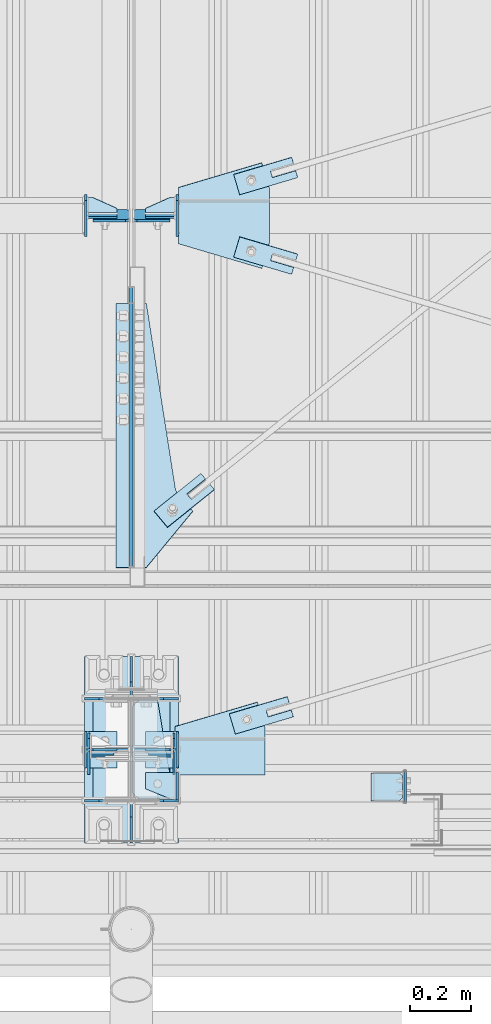
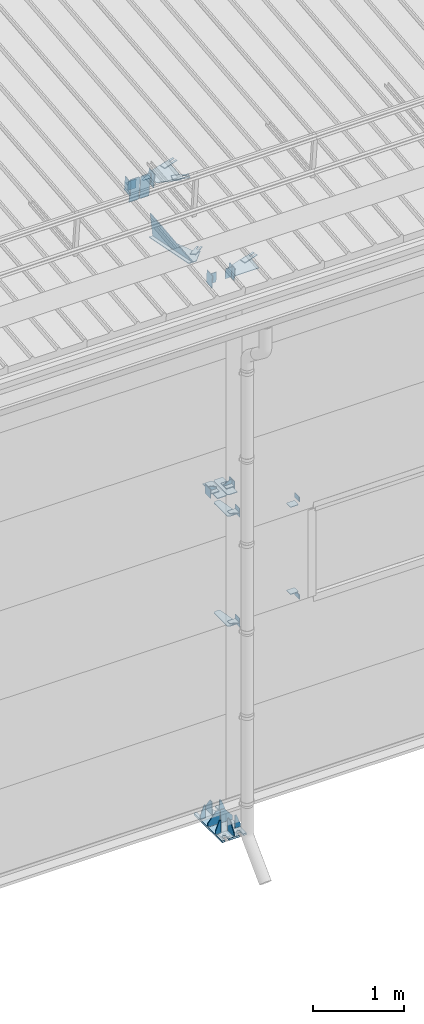
# One storey, part 145 of 709: 47 plates, 7 openings, 15 elements without a shape of their own.
"""IFC4 building model written with IfcOpenShell, lengths in millimetres."""

from ifc_helpers import new_model, si_unit, direction, frame, origin_with_axes, place, context, subcontext, project, spatial, line, arc, indexed_curve, outline, extrude, material, element, aggregate, save


model = new_model("IFC4")

# Units and contexts
model_context = context("Model", 3, precision=0.2, world=origin_with_axes(), true_north=direction((0.0, 1.0)))
body_context = subcontext(model_context, "Body", "Model", "MODEL_VIEW")
ifc_project = project(units=[si_unit("LENGTHUNIT", "METRE", prefix="MILLI"), si_unit("AREAUNIT", "SQUARE_METRE"), si_unit("VOLUMEUNIT", "CUBIC_METRE"), si_unit("MASSUNIT", "GRAM", prefix="KILO"), si_unit("TIMEUNIT", "SECOND"), si_unit("PLANEANGLEUNIT", "RADIAN"), si_unit("SOLIDANGLEUNIT", "STERADIAN"), si_unit("THERMODYNAMICTEMPERATUREUNIT", "DEGREE_CELSIUS"), si_unit("LUMINOUSINTENSITYUNIT", "LUMEN")], contexts=[model_context])

# Site, building, storey
site_placement = place(None, origin_with_axes())
site = spatial("IfcSite", under=ifc_project, at=site_placement, CompositionType="ELEMENT")
building_placement = place(site_placement, origin_with_axes())
building = spatial("IfcBuilding", under=site, at=building_placement, Name="Undefined", CompositionType="ELEMENT")
storey_placement = place(building_placement, origin_with_axes())
storey = spatial("IfcBuildingStorey", under=building, at=storey_placement, Name="Undefined", CompositionType="ELEMENT", Elevation=0.0)

# Assembly, plates, voiding features
assembly_1_placement = place(storey_placement, frame((40000.0, 173.0, -200.0), z_axis=(-1.0, 0.0, 0.0), x_axis=(0.0, 0.0, 1.0)))
assembly_1 = element("IfcElementAssembly", 1, at=assembly_1_placement, inside=storey)
ifc_material = material(Name="C355-6", Category="STEEL")
plate_1_placement = place(assembly_1_placement, frame((25.0, 168.5, -87.0), z_axis=(0.0, -1.0, 0.0), x_axis=(0.0, 0.0, -1.0)))
plate_1 = element("IfcPlate", 2, at=plate_1_placement, material=ifc_material, ObjectType="419", context=body_context, shape_type="SolidModel", body=[
    extrude(outline(indexed_curve([(0.0, 0.0), (68.0, 0.0), (68.0, 50.0), (20.0, 175.0), (0.0, 175.0)], segments=[line(1, 2, 3, 4, 5, 1)])), frame((0.0, 0.0, 4.0), z_axis=(0.0, 0.0, 1.0), x_axis=(1.0, 0.0, 0.0)), (0.0, 0.0, -1.0), 8.0),
])
plate_2_placement = place(assembly_1_placement, frame((25.0, -168.5, -87.0), z_axis=(0.0, -1.0, 0.0), x_axis=(0.0, 0.0, -1.0)))
plate_2 = element("IfcPlate", 3, at=plate_2_placement, material=ifc_material, ObjectType="419", context=body_context, shape_type="SolidModel", body=[
    extrude(outline(indexed_curve([(0.0, 0.0), (68.0, 0.0), (68.0, 50.0), (20.0, 175.0), (0.0, 175.0)], segments=[line(1, 2, 3, 4, 5, 1)])), frame((0.0, 0.0, 4.0), z_axis=(0.0, 0.0, 1.0), x_axis=(1.0, 0.0, 0.0)), (0.0, 0.0, -1.0), 8.0),
])
plate_3_placement = place(assembly_1_placement, frame((25.0, 173.0, 0.0), z_axis=(0.0, 0.0, -1.0), x_axis=(0.0, 1.0, 0.0)))
plate_3 = element("IfcPlate", 4, at=plate_3_placement, material=ifc_material, ObjectType="418", context=body_context, shape_type="SolidModel", body=[
    extrude(outline(indexed_curve([(0.0, 0.0), (135.0, 0.0), (135.0, 50.0), (50.0, 175.0), (0.0, 175.0)], segments=[line(1, 2, 3, 4, 5, 1)])), frame((0.0, 0.0, 4.0), z_axis=(0.0, 0.0, 1.0), x_axis=(1.0, 0.0, 0.0)), (0.0, 0.0, -1.0), 8.0),
])
plate_4_placement = place(assembly_1_placement, frame((25.0, 0.0, 3.0), z_axis=(0.0, 1.0, 0.0), x_axis=(0.0, 0.0, 1.0)))
plate_4 = element("IfcPlate", 5, at=plate_4_placement, material=ifc_material, ObjectType="417", context=body_context, shape_type="SolidModel", body=[
    extrude(outline(indexed_curve([(0.0, 0.0), (152.0, 0.0), (152.0, 50.0), (50.0, 175.0), (0.0, 175.0)], segments=[line(1, 2, 3, 4, 5, 1)])), frame((0.0, 0.0, 4.0), z_axis=(0.0, 0.0, 1.0), x_axis=(1.0, 0.0, 0.0)), (0.0, 0.0, -1.0), 8.0),
])
plate_5_placement = place(assembly_1_placement, frame((25.0, -168.5, 87.0), z_axis=(0.0, 1.0, 0.0), x_axis=(0.0, 0.0, 1.0)))
plate_5 = element("IfcPlate", 6, at=plate_5_placement, material=ifc_material, ObjectType="419", context=body_context, shape_type="SolidModel", body=[
    extrude(outline(indexed_curve([(0.0, 0.0), (68.0, 0.0), (68.0, 50.0), (20.0, 175.0), (0.0, 175.0)], segments=[line(1, 2, 3, 4, 5, 1)])), frame((0.0, 0.0, 4.0), z_axis=(0.0, 0.0, 1.0), x_axis=(1.0, 0.0, 0.0)), (0.0, 0.0, -1.0), 8.0),
])
plate_6_placement = place(assembly_1_placement, frame((25.0, 0.0, -3.0), z_axis=(0.0, -1.0, 0.0), x_axis=(0.0, 0.0, -1.0)))
plate_6 = element("IfcPlate", 7, at=plate_6_placement, material=ifc_material, ObjectType="417", context=body_context, shape_type="SolidModel", body=[
    extrude(outline(indexed_curve([(0.0, 0.0), (152.0, 0.0), (152.0, 50.0), (50.0, 175.0), (0.0, 175.0)], segments=[line(1, 2, 3, 4, 5, 1)])), frame((0.0, 0.0, 4.0), z_axis=(0.0, 0.0, 1.0), x_axis=(1.0, 0.0, 0.0)), (0.0, 0.0, -1.0), 8.0),
])
plate_7_placement = place(assembly_1_placement, frame((25.0, 168.5, 87.0), z_axis=(0.0, 1.0, 0.0), x_axis=(0.0, 0.0, 1.0)))
plate_7 = element("IfcPlate", 8, at=plate_7_placement, material=ifc_material, ObjectType="419", context=body_context, shape_type="SolidModel", body=[
    extrude(outline(indexed_curve([(0.0, 0.0), (68.0, 0.0), (68.0, 50.0), (20.0, 175.0), (0.0, 175.0)], segments=[line(1, 2, 3, 4, 5, 1)])), frame((0.0, 0.0, 4.0), z_axis=(0.0, 0.0, 1.0), x_axis=(1.0, 0.0, 0.0)), (0.0, 0.0, -1.0), 8.0),
])
plate_8_placement = place(assembly_1_placement, frame((12.5, -308.0, 155.0), z_axis=(1.0, 0.0, 0.0), x_axis=(0.0, 0.0, -1.0)))
plate_8 = element("IfcPlate", 9, at=plate_8_placement, material=ifc_material, ObjectType="416", context=body_context, shape_type="SolidModel", body=[
    extrude(outline(indexed_curve([(0.0, 0.0), (310.0, 0.0), (310.0, 616.0), (0.0, 616.0)], segments=[line(1, 2, 3, 4, 1)])), frame((0.0, 0.0, 12.5), z_axis=(0.0, 0.0, 1.0), x_axis=(1.0, 0.0, 0.0)), (0.0, 0.0, -1.0), 25.0),
])
voiding_feature_1_placement = place(plate_8_placement, frame((40.0, 616.0, 0.0), z_axis=(0.0, 0.0, -1.0), x_axis=(1.0, 0.0, 0.0)))
element("IfcVoidingFeature", 10, at=voiding_feature_1_placement, cuts=plate_8, PredefinedType="HOLE", context=body_context, shape_type="SolidModel", body=[
    extrude(outline(indexed_curve([(0.0, 0.0), (50.0, 0.0), (50.0, 60.0), (42.67767, 77.67767), (25.0, 85.0), (25.0, 85.0), (7.32233, 77.67767), (0.0, 60.0)], segments=[line(1, 2, 3), arc(3, 4, 5), line(5, 6), arc(6, 7, 8), line(8, 1)])), frame((0.0, 0.0, 12.5), z_axis=(0.0, 0.0, 1.0), x_axis=(1.0, 0.0, 0.0)), (0.0, 0.0, -1.0), 25.0),
])
voiding_feature_2_placement = place(plate_8_placement, frame((40.0, 0.0, 0.0), z_axis=(0.0, 0.0, 1.0), x_axis=(1.0, 0.0, 0.0)))
element("IfcVoidingFeature", 11, at=voiding_feature_2_placement, cuts=plate_8, PredefinedType="HOLE", context=body_context, shape_type="SolidModel", body=[
    extrude(outline(indexed_curve([(0.0, 0.0), (50.0, 0.0), (50.0, 60.0), (42.67767, 77.67767), (25.0, 85.0), (25.0, 85.0), (7.32233, 77.67767), (0.0, 60.0)], segments=[line(1, 2, 3), arc(3, 4, 5), line(5, 6), arc(6, 7, 8), line(8, 1)])), frame((0.0, 0.0, 12.5), z_axis=(0.0, 0.0, 1.0), x_axis=(1.0, 0.0, 0.0)), (0.0, 0.0, -1.0), 25.0),
])
voiding_feature_3_placement = place(plate_8_placement, frame((270.0, 616.0, 0.0), z_axis=(0.0, 0.0, 1.0), x_axis=(-1.0, 0.0, 0.0)))
element("IfcVoidingFeature", 12, at=voiding_feature_3_placement, cuts=plate_8, PredefinedType="HOLE", context=body_context, shape_type="SolidModel", body=[
    extrude(outline(indexed_curve([(0.0, 0.0), (50.0, 0.0), (50.0, 60.0), (42.67767, 77.67767), (25.0, 85.0), (25.0, 85.0), (7.32233, 77.67767), (0.0, 60.0)], segments=[line(1, 2, 3), arc(3, 4, 5), line(5, 6), arc(6, 7, 8), line(8, 1)])), frame((0.0, 0.0, 12.5), z_axis=(0.0, 0.0, 1.0), x_axis=(1.0, 0.0, 0.0)), (0.0, 0.0, -1.0), 25.0),
])
voiding_feature_4_placement = place(plate_8_placement, frame((270.0, 0.0, 0.0), z_axis=(0.0, 0.0, -1.0), x_axis=(-1.0, 0.0, 0.0)))
element("IfcVoidingFeature", 13, at=voiding_feature_4_placement, cuts=plate_8, PredefinedType="HOLE", context=body_context, shape_type="SolidModel", body=[
    extrude(outline(indexed_curve([(0.0, 0.0), (50.0, 0.0), (50.0, 60.0), (42.67767, 77.67767), (25.0, 85.0), (25.0, 85.0), (7.32233, 77.67767), (0.0, 60.0)], segments=[line(1, 2, 3), arc(3, 4, 5), line(5, 6), arc(6, 7, 8), line(8, 1)])), frame((0.0, 0.0, 12.5), z_axis=(0.0, 0.0, 1.0), x_axis=(1.0, 0.0, 0.0)), (0.0, 0.0, -1.0), 25.0),
])
plate_9_placement = place(assembly_1_placement, frame((25.0, -173.0, 0.0), z_axis=(0.0, 0.0, 1.0), x_axis=(0.0, -1.0, 0.0)))
plate_9 = element("IfcPlate", 14, at=plate_9_placement, material=ifc_material, ObjectType="418", context=body_context, shape_type="SolidModel", body=[
    extrude(outline(indexed_curve([(0.0, 0.0), (135.0, 0.0), (135.0, 50.0), (50.0, 175.0), (0.0, 175.0)], segments=[line(1, 2, 3, 4, 5, 1)])), frame((0.0, 0.0, 4.0), z_axis=(0.0, 0.0, 1.0), x_axis=(1.0, 0.0, 0.0)), (0.0, 0.0, -1.0), 8.0),
])
plate_10_placement = place(assembly_1_placement, frame((4502.0, 163.0, 127.0), z_axis=(-1.0, 0.0, 0.0), x_axis=(0.0, 0.0, -1.0)))
plate_10 = element("IfcPlate", 15, at=plate_10_placement, material=ifc_material, ObjectType="547", context=body_context, shape_type="SolidModel", body=[
    extrude(outline(indexed_curve([(0.0, 0.0), (108.0, 0.0), (123.0, 15.0), (123.0, 311.0), (108.0, 326.0), (0.0, 326.0)], segments=[line(1, 2, 3, 4, 5, 6, 1)])), frame((0.0, 0.0, 4.0), z_axis=(0.0, 0.0, 1.0), x_axis=(1.0, 0.0, 0.0)), (0.0, 0.0, -1.0), 8.0),
])
plate_11_placement = place(assembly_1_placement, frame((2742.0, -163.0, -4.0), z_axis=(1.0, 0.0, 0.0), x_axis=(0.0, 0.0, -1.0)))
plate_11 = element("IfcPlate", 16, at=plate_11_placement, material=ifc_material, ObjectType="543", context=body_context, shape_type="SolidModel", body=[
    extrude(outline(indexed_curve([(0.0, 20.0), (20.0, 0.0), (123.0, 0.0), (123.0, 86.0), (83.0, 326.0), (20.0, 326.0), (0.0, 306.0)], segments=[line(1, 2, 3, 4, 5, 6, 7, 1)])), frame((0.0, 0.0, 4.0), z_axis=(0.0, 0.0, 1.0), x_axis=(1.0, 0.0, 0.0)), (0.0, 0.0, -1.0), 8.0),
])
plate_12_placement = place(assembly_1_placement, frame((4212.0, -163.0, -4.0), z_axis=(1.0, 0.0, 0.0), x_axis=(0.0, 0.0, -1.0)))
plate_12 = element("IfcPlate", 17, at=plate_12_placement, material=ifc_material, ObjectType="543", context=body_context, shape_type="SolidModel", body=[
    extrude(outline(indexed_curve([(0.0, 20.0), (20.0, 0.0), (123.0, 0.0), (123.0, 86.0), (83.0, 326.0), (20.0, 326.0), (0.0, 306.0)], segments=[line(1, 2, 3, 4, 5, 6, 7, 1)])), frame((0.0, 0.0, 4.0), z_axis=(0.0, 0.0, 1.0), x_axis=(1.0, 0.0, 0.0)), (0.0, 0.0, -1.0), 8.0),
])
plate_13_placement = place(assembly_1_placement, frame((4502.0, -163.0, -127.0), z_axis=(-1.0, 0.0, 0.0), x_axis=(0.0, 0.0, 1.0)))
plate_13 = element("IfcPlate", 18, at=plate_13_placement, material=ifc_material, ObjectType="547", context=body_context, shape_type="SolidModel", body=[
    extrude(outline(indexed_curve([(0.0, 0.0), (108.0, 0.0), (123.0, 15.0), (123.0, 311.0), (108.0, 326.0), (0.0, 326.0)], segments=[line(1, 2, 3, 4, 5, 6, 1)])), frame((0.0, 0.0, 4.0), z_axis=(0.0, 0.0, 1.0), x_axis=(1.0, 0.0, 0.0)), (0.0, 0.0, -1.0), 8.0),
])
aggregate(assembly_1, [plate_1, plate_2, plate_3, plate_4, plate_5, plate_6, plate_7, plate_8, plate_9, plate_10, plate_11, plate_12, plate_13])

# Assembly, plates
assembly_2_placement = place(storey_placement, frame((40000.0, 346.0, 7089.70002), z_axis=(1.0, 0.0, 0.0), x_axis=(0.0, 0.9950371902, 0.099503719)))
assembly_2 = element("IfcElementAssembly", 19, at=assembly_2_placement, inside=storey)
plate_14_placement = place(assembly_2_placement, frame((1597.88359, 163.0, 127.0), z_axis=(-1.0, 0.0, 0.0), x_axis=(0.0, 0.0, -1.0)))
plate_14 = element("IfcPlate", 20, at=plate_14_placement, material=ifc_material, ObjectType="585", context=body_context, shape_type="SolidModel", body=[
    extrude(outline(indexed_curve([(0.0, 0.0), (108.0, 0.0), (123.0, 15.0), (123.0, 311.0), (108.0, 326.0), (0.0, 326.0)], segments=[line(1, 2, 3, 4, 5, 6, 1)])), frame((0.0, 0.0, 4.0), z_axis=(0.0, 0.0, 1.0), x_axis=(1.0, 0.0, 0.0)), (0.0, 0.0, -1.0), 8.0),
])
plate_15_placement = place(assembly_2_placement, frame((1597.88359, 163.0, -127.0), z_axis=(1.0, 0.0, 0.0), x_axis=(0.0, 0.0, 1.0)))
plate_15 = element("IfcPlate", 21, at=plate_15_placement, material=ifc_material, ObjectType="585", context=body_context, shape_type="SolidModel", body=[
    extrude(outline(indexed_curve([(0.0, 0.0), (108.0, 0.0), (123.0, 15.0), (123.0, 311.0), (108.0, 326.0), (0.0, 326.0)], segments=[line(1, 2, 3, 4, 5, 6, 1)])), frame((0.0, 0.0, 4.0), z_axis=(0.0, 0.0, 1.0), x_axis=(1.0, 0.0, 0.0)), (0.0, 0.0, -1.0), 8.0),
])
plate_16_placement = place(assembly_2_placement, frame((1342.111, -173.0, 0.0), z_axis=(0.0, 0.0, 1.0), x_axis=(-1.0, 0.0, 0.0)))
plate_16 = element("IfcPlate", 22, at=plate_16_placement, material=ifc_material, ObjectType="449", context=body_context, shape_type="SolidModel", body=[
    extrude(outline(indexed_curve([(0.0, 0.0), (928.3198, 0.0), (79.53997, 259.83056)], segments=[line(1, 2, 3, 1)])), frame((0.0, 0.0, 6.0), z_axis=(0.0, 0.0, 1.0), x_axis=(1.0, 0.0, 0.0)), (0.0, 0.0, -1.0), 12.0),
])
plate_17_placement = place(assembly_2_placement, frame((1261.40018, -436.65536, -50.0), z_axis=(0.2927142719, 0.9561999556, 0.0), x_axis=(-0.9561999556, 0.2927142719, 0.0)))
plate_17 = element("IfcPlate", 23, at=plate_17_placement, material=ifc_material, ObjectType="489", context=body_context, shape_type="SolidModel", body=[
    extrude(outline(indexed_curve([(0.0, 0.0), (887.65935, 0.0), (887.65935, 100.0), (698.2863, 253.1922), (628.6057, 196.23068), (0.0, 100.0)], segments=[line(1, 2, 3, 4, 5, 6, 1)])), frame((0.0, 0.0, 4.0), z_axis=(0.0, 0.0, 1.0), x_axis=(1.0, 0.0, 0.0)), (0.0, 0.0, -1.0), 8.0),
])
aggregate(assembly_2, [plate_14, plate_15, plate_16, plate_17])

# Assembly, plate
assembly_3_placement = place(storey_placement, frame((40000.0, 855.54834, 6946.69226), z_axis=(0.625451877, -0.7802627439, 1e-10), x_axis=(0.7742288439, 0.6206151549, -0.124123031)))
assembly_3 = element("IfcElementAssembly", 24, at=assembly_3_placement, inside=storey)
plate_18_placement = place(assembly_3_placement, frame((325.65866, 5.35577, 34.5878), z_axis=(0.0, -0.9882227647, 0.1530221141), x_axis=(-1.0, 0.0, 0.0)))
plate_18 = element("IfcPlate", 25, at=plate_18_placement, material=ifc_material, ObjectType="490", context=body_context, shape_type="SolidModel", body=[
    extrude(outline(indexed_curve([(0.0, 0.0), (200.0, 0.0), (200.0, 70.0), (0.0, 70.0), (0.0, 46.0), (80.0, 46.0), (80.0, 24.0), (0.0, 24.0)], segments=[line(1, 2, 3, 4, 5, 6, 7, 8, 1)])), frame((0.0, 0.0, 4.0), z_axis=(0.0, 0.0, 1.0), x_axis=(1.0, 0.0, 0.0)), (0.0, 0.0, -1.0), 8.0),
])
aggregate(assembly_3, [plate_18])

# Assembly, plates
assembly_4_placement = place(storey_placement, frame((34000.0, 173.0, 4310.0), z_axis=(0.0, 0.0, -1.0), x_axis=(1.0, 0.0, 0.0)))
assembly_4 = element("IfcElementAssembly", 26, at=assembly_4_placement, inside=storey)
plate_19_placement = place(assembly_4_placement, frame((5849.0, -60.0, 60.0), z_axis=(1.0, 0.0, 0.0), x_axis=(0.0, 0.0, -1.0)))
plate_19 = element("IfcPlate", 27, at=plate_19_placement, material=ifc_material, ObjectType="506", context=body_context, shape_type="SolidModel", body=[
    extrude(outline(indexed_curve([(0.0, 0.0), (120.0, 0.0), (120.0, 120.0), (0.0, 120.0)], segments=[line(1, 2, 3, 4, 1)])), frame((0.0, 0.0, 4.0), z_axis=(0.0, 0.0, 1.0), x_axis=(1.0, 0.0, 0.0)), (0.0, 0.0, -1.0), 8.0),
])
plate_20_placement = place(assembly_4_placement, frame((5953.0, -60.0, 0.0), z_axis=(0.0, 0.0, 1.0), x_axis=(0.0, 1.0, 0.0)))
plate_20 = element("IfcPlate", 28, at=plate_20_placement, material=ifc_material, ObjectType="507", context=body_context, shape_type="SolidModel", body=[
    extrude(outline(indexed_curve([(0.0, 0.0), (120.0, 0.0), (120.0, 100.0), (0.0, 100.0)], segments=[line(1, 2, 3, 4, 1)])), frame((0.0, 0.0, 4.0), z_axis=(0.0, 0.0, 1.0), x_axis=(1.0, 0.0, 0.0)), (0.0, 0.0, -1.0), 8.0),
])
plate_21_placement = place(assembly_4_placement, frame((5953.0, 0.0, -60.0), z_axis=(0.0, -1.0, 0.0), x_axis=(0.0, 0.0, 1.0)))
plate_21 = element("IfcPlate", 29, at=plate_21_placement, material=ifc_material, ObjectType="508", context=body_context, shape_type="SolidModel", body=[
    extrude(outline(indexed_curve([(0.0, 80.0), (36.0, 0.0), (56.0, 0.0), (56.0, 90.0), (46.0, 100.0), (0.0, 100.0)], segments=[line(1, 2, 3, 4, 5, 6, 1)])), frame((0.0, 0.0, 4.0), z_axis=(0.0, 0.0, 1.0), x_axis=(1.0, 0.0, 0.0)), (0.0, 0.0, -1.0), 8.0),
])
aggregate(assembly_4, [plate_19, plate_20, plate_21])

assembly_5_placement = place(storey_placement, frame((40000.0, 50.0, 2550.0), z_axis=(0.0, 0.0, -1.0), x_axis=(1.0, 0.0, 0.0)))
assembly_5 = element("IfcElementAssembly", 30, at=assembly_5_placement, inside=storey)
plate_22_placement = place(assembly_5_placement, frame((151.0, 47.0, -60.0), z_axis=(-1.0, 0.0, 0.0), x_axis=(0.0, -1.0, 0.0)))
plate_22 = element("IfcPlate", 31, at=plate_22_placement, material=ifc_material, ObjectType="501", context=body_context, shape_type="SolidModel", body=[
    extrude(outline(indexed_curve([(0.0, 0.0), (94.0, 0.0), (94.0, 120.0), (0.0, 120.0)], segments=[line(1, 2, 3, 4, 1)])), frame((0.0, 0.0, 4.0), z_axis=(0.0, 0.0, 1.0), x_axis=(1.0, 0.0, 0.0)), (0.0, 0.0, -1.0), 8.0),
])
plate_23_placement = place(assembly_5_placement, frame((47.0, 47.0, 0.0), z_axis=(0.0, 0.0, 1.0), x_axis=(0.0, -1.0, 0.0)))
plate_23 = element("IfcPlate", 32, at=plate_23_placement, material=ifc_material, ObjectType="502", context=body_context, shape_type="SolidModel", body=[
    extrude(outline(indexed_curve([(0.0, 100.0), (40.0, 0.0), (94.0, 0.0), (94.0, 100.0), (0.0, 100.0)], segments=[line(1, 2, 3, 4, 5, 1)])), frame((0.0, 0.0, 4.0), z_axis=(0.0, 0.0, 1.0), x_axis=(1.0, 0.0, 0.0)), (0.0, 0.0, -1.0), 8.0),
])
plate_24_placement = place(assembly_5_placement, frame((904.0, 50.0, -50.0), z_axis=(-1.0, 0.0, 0.0), x_axis=(0.0, 0.0, -1.0)))
plate_24 = element("IfcPlate", 33, at=plate_24_placement, material=ifc_material, ObjectType="509", context=body_context, shape_type="SolidModel", body=[
    extrude(outline(indexed_curve([(0.0, 0.0), (65.0, 0.0), (65.0, 100.0), (0.0, 100.0)], segments=[line(1, 2, 3, 4, 1)])), frame((0.0, 0.0, 4.0), z_axis=(0.0, 0.0, 1.0), x_axis=(1.0, 0.0, 0.0)), (0.0, 0.0, -1.0), 8.0),
])
aggregate(assembly_5, [plate_22, plate_23, plate_24])

assembly_6_placement = place(storey_placement, frame((40000.0, 50.0, 4020.0), z_axis=(0.0, 0.0, -1.0), x_axis=(1.0, 0.0, 0.0)))
assembly_6 = element("IfcElementAssembly", 34, at=assembly_6_placement, inside=storey)
plate_25_placement = place(assembly_6_placement, frame((47.0, 47.0, 0.0), z_axis=(0.0, 0.0, 1.0), x_axis=(0.0, -1.0, 0.0)))
plate_25 = element("IfcPlate", 35, at=plate_25_placement, material=ifc_material, ObjectType="502", context=body_context, shape_type="SolidModel", body=[
    extrude(outline(indexed_curve([(0.0, 100.0), (40.0, 0.0), (94.0, 0.0), (94.0, 100.0), (0.0, 100.0)], segments=[line(1, 2, 3, 4, 5, 1)])), frame((0.0, 0.0, 4.0), z_axis=(0.0, 0.0, 1.0), x_axis=(1.0, 0.0, 0.0)), (0.0, 0.0, -1.0), 8.0),
])
plate_26_placement = place(assembly_6_placement, frame((151.0, 47.0, -60.0), z_axis=(-1.0, 0.0, 0.0), x_axis=(0.0, -1.0, 0.0)))
plate_26 = element("IfcPlate", 36, at=plate_26_placement, material=ifc_material, ObjectType="501", context=body_context, shape_type="SolidModel", body=[
    extrude(outline(indexed_curve([(0.0, 0.0), (94.0, 0.0), (94.0, 120.0), (0.0, 120.0)], segments=[line(1, 2, 3, 4, 1)])), frame((0.0, 0.0, 4.0), z_axis=(0.0, 0.0, 1.0), x_axis=(1.0, 0.0, 0.0)), (0.0, 0.0, -1.0), 8.0),
])
plate_27_placement = place(assembly_6_placement, frame((904.0, -50.0, 50.0), z_axis=(-1.0, 0.0, 0.0), x_axis=(0.0, 0.0, 1.0)))
plate_27 = element("IfcPlate", 37, at=plate_27_placement, material=ifc_material, ObjectType="509", context=body_context, shape_type="SolidModel", body=[
    extrude(outline(indexed_curve([(0.0, 0.0), (65.0, 0.0), (65.0, 100.0), (0.0, 100.0)], segments=[line(1, 2, 3, 4, 1)])), frame((0.0, 0.0, 4.0), z_axis=(0.0, 0.0, 1.0), x_axis=(1.0, 0.0, 0.0)), (0.0, 0.0, -1.0), 8.0),
])
aggregate(assembly_6, [plate_25, plate_26, plate_27])

assembly_7_placement = place(storey_placement, frame((40850.0, 50.0, 2600.0), z_axis=(1.0, 0.0, 0.0), x_axis=(0.0, 0.0, 1.0)))
assembly_7 = element("IfcElementAssembly", 38, at=assembly_7_placement, inside=storey)
plate_28_placement = place(assembly_7_placement, frame((1267.0, 46.0, 46.0), z_axis=(1.0, 0.0, 0.0), x_axis=(0.0, -1.0, 0.0)))
plate_28 = element("IfcPlate", 39, at=plate_28_placement, material=ifc_material, ObjectType="510", context=body_context, shape_type="SolidModel", body=[
    extrude(outline(indexed_curve([(0.0, 10.0), (10.0, 0.0), (82.0, 0.0), (92.0, 10.0), (92.0, 104.0), (0.0, 104.0)], segments=[line(1, 2, 3, 4, 5, 6, 1)])), frame((0.0, 0.0, 4.0), z_axis=(0.0, 0.0, 1.0), x_axis=(1.0, 0.0, 0.0)), (0.0, 0.0, -1.0), 8.0),
])
plate_29_placement = place(assembly_7_placement, frame((103.0, -46.0, 46.0), z_axis=(-1.0, 0.0, 0.0), x_axis=(0.0, 1.0, 0.0)))
plate_29 = element("IfcPlate", 40, at=plate_29_placement, material=ifc_material, ObjectType="510", context=body_context, shape_type="SolidModel", body=[
    extrude(outline(indexed_curve([(0.0, 10.0), (10.0, 0.0), (82.0, 0.0), (92.0, 10.0), (92.0, 104.0), (0.0, 104.0)], segments=[line(1, 2, 3, 4, 5, 6, 1)])), frame((0.0, 0.0, 4.0), z_axis=(0.0, 0.0, 1.0), x_axis=(1.0, 0.0, 0.0)), (0.0, 0.0, -1.0), 8.0),
])
aggregate(assembly_7, [plate_28, plate_29])

assembly_8_placement = place(storey_placement, frame((40000.0, 173.0, 4310.0), z_axis=(0.0, 0.0, -1.0), x_axis=(1.0, 0.0, 0.0)))
assembly_8 = element("IfcElementAssembly", 41, at=assembly_8_placement, inside=storey)
plate_30_placement = place(assembly_8_placement, frame((47.0, 0.0, -60.0), z_axis=(0.0, 1.0, 0.0), x_axis=(0.0, 0.0, 1.0)))
plate_30 = element("IfcPlate", 42, at=plate_30_placement, material=ifc_material, ObjectType="508", context=body_context, shape_type="SolidModel", body=[
    extrude(outline(indexed_curve([(0.0, 80.0), (36.0, 0.0), (56.0, 0.0), (56.0, 90.0), (46.0, 100.0), (0.0, 100.0)], segments=[line(1, 2, 3, 4, 5, 6, 1)])), frame((0.0, 0.0, 4.0), z_axis=(0.0, 0.0, 1.0), x_axis=(1.0, 0.0, 0.0)), (0.0, 0.0, -1.0), 8.0),
])
plate_31_placement = place(assembly_8_placement, frame((151.0, 60.0, 60.0), z_axis=(-1.0, 0.0, 0.0), x_axis=(0.0, 0.0, -1.0)))
plate_31 = element("IfcPlate", 43, at=plate_31_placement, material=ifc_material, ObjectType="506", context=body_context, shape_type="SolidModel", body=[
    extrude(outline(indexed_curve([(0.0, 0.0), (120.0, 0.0), (120.0, 120.0), (0.0, 120.0)], segments=[line(1, 2, 3, 4, 1)])), frame((0.0, 0.0, 4.0), z_axis=(0.0, 0.0, 1.0), x_axis=(1.0, 0.0, 0.0)), (0.0, 0.0, -1.0), 8.0),
])
plate_32_placement = place(assembly_8_placement, frame((47.0, 60.0, 0.0), z_axis=(0.0, 0.0, 1.0), x_axis=(0.0, -1.0, 0.0)))
plate_32 = element("IfcPlate", 44, at=plate_32_placement, material=ifc_material, ObjectType="507", context=body_context, shape_type="SolidModel", body=[
    extrude(outline(indexed_curve([(0.0, 0.0), (120.0, 0.0), (120.0, 100.0), (0.0, 100.0)], segments=[line(1, 2, 3, 4, 1)])), frame((0.0, 0.0, 4.0), z_axis=(0.0, 0.0, 1.0), x_axis=(1.0, 0.0, 0.0)), (0.0, 0.0, -1.0), 8.0),
])
aggregate(assembly_8, [plate_30, plate_31, plate_32])

# Assembly, plate, voiding feature
assembly_9_placement = place(storey_placement, frame((40000.0, 159.15434, 7152.41945), z_axis=(0.2852311229, -0.9537021177, -0.0953702118), x_axis=(0.9584587662, 0.2838155751, 0.028381558)))
assembly_9 = element("IfcElementAssembly", 45, at=assembly_9_placement, inside=storey)
plate_33_placement = place(assembly_9_placement, frame((348.0251, 0.0, -35.0), z_axis=(0.0, 1.0, 0.0), x_axis=(0.0, 0.0, 1.0)))
plate_33 = element("IfcPlate", 46, at=plate_33_placement, material=ifc_material, ObjectType="574", context=body_context, shape_type="SolidModel", body=[
    extrude(outline(indexed_curve([(0.0, 0.0), (70.0, 0.0), (70.0, 200.0), (0.0, 200.0)], segments=[line(1, 2, 3, 4, 1)])), frame((0.0, 0.0, 4.0), z_axis=(0.0, 0.0, 1.0), x_axis=(1.0, 0.0, 0.0)), (0.0, 0.0, -1.0), 8.0),
])
voiding_feature_5_placement = place(plate_33_placement, frame((24.0, 120.0, 0.0), z_axis=(0.0, 0.0, 1.0), x_axis=(1.0, 0.0, 0.0)))
element("IfcVoidingFeature", 47, at=voiding_feature_5_placement, cuts=plate_33, Name="PLATE", PredefinedType="HOLE", context=body_context, shape_type="SolidModel", body=[
    extrude(outline(indexed_curve([(0.0, 0.0), (22.0, 0.0), (22.0, 85.0), (0.0, 85.0)], segments=[line(1, 2, 3, 4, 1)])), frame((0.0, 0.0, 6.5), z_axis=(0.0, 0.0, 1.0), x_axis=(1.0, 0.0, 0.0)), (0.0, 0.0, -1.0), 13.0),
])
aggregate(assembly_9, [plate_33])

assembly_10_placement = place(storey_placement, frame((40000.0, 1935.85409, 7330.08943), z_axis=(-0.2852311229, -0.9537021177, -0.0953702118), x_axis=(0.9584587662, -0.2838155751, -0.028381558)))
assembly_10 = element("IfcElementAssembly", 48, at=assembly_10_placement, inside=storey)
plate_34_placement = place(assembly_10_placement, frame((363.0251, 0.0, -35.0), z_axis=(0.0, 1.0, 0.0), x_axis=(0.0, 0.0, 1.0)))
plate_34 = element("IfcPlate", 49, at=plate_34_placement, material=ifc_material, ObjectType="574", context=body_context, shape_type="SolidModel", body=[
    extrude(outline(indexed_curve([(0.0, 0.0), (70.0, 0.0), (70.0, 200.0), (0.0, 200.0)], segments=[line(1, 2, 3, 4, 1)])), frame((0.0, 0.0, 4.0), z_axis=(0.0, 0.0, 1.0), x_axis=(1.0, 0.0, 0.0)), (0.0, 0.0, -1.0), 8.0),
])
voiding_feature_6_placement = place(plate_34_placement, frame((24.0, 120.0, 0.0), z_axis=(0.0, 0.0, 1.0), x_axis=(1.0, 0.0, 0.0)))
element("IfcVoidingFeature", 50, at=voiding_feature_6_placement, cuts=plate_34, Name="PLATE", PredefinedType="HOLE", context=body_context, shape_type="SolidModel", body=[
    extrude(outline(indexed_curve([(0.0, 0.0), (22.0, 0.0), (22.0, 85.0), (0.0, 85.0)], segments=[line(1, 2, 3, 4, 1)])), frame((0.0, 0.0, 6.5), z_axis=(0.0, 0.0, 1.0), x_axis=(1.0, 0.0, 0.0)), (0.0, 0.0, -1.0), 13.0),
])
aggregate(assembly_10, [plate_34])

assembly_11_placement = place(storey_placement, frame((40000.0, 1935.85409, 7330.08943), z_axis=(0.2852311229, -0.9537021177, -0.0953702118), x_axis=(0.9584587662, 0.2838155751, 0.028381558)))
assembly_11 = element("IfcElementAssembly", 51, at=assembly_11_placement, inside=storey)
plate_35_placement = place(assembly_11_placement, frame((363.0251, 0.0, -35.0), z_axis=(0.0, 1.0, 0.0), x_axis=(0.0, 0.0, 1.0)))
plate_35 = element("IfcPlate", 52, at=plate_35_placement, material=ifc_material, ObjectType="574", context=body_context, shape_type="SolidModel", body=[
    extrude(outline(indexed_curve([(0.0, 0.0), (70.0, 0.0), (70.0, 200.0), (0.0, 200.0)], segments=[line(1, 2, 3, 4, 1)])), frame((0.0, 0.0, 4.0), z_axis=(0.0, 0.0, 1.0), x_axis=(1.0, 0.0, 0.0)), (0.0, 0.0, -1.0), 8.0),
])
voiding_feature_7_placement = place(plate_35_placement, frame((24.0, 120.0, 0.0), z_axis=(0.0, 0.0, 1.0), x_axis=(1.0, 0.0, 0.0)))
element("IfcVoidingFeature", 53, at=voiding_feature_7_placement, cuts=plate_35, Name="PLATE", PredefinedType="HOLE", context=body_context, shape_type="SolidModel", body=[
    extrude(outline(indexed_curve([(0.0, 0.0), (22.0, 0.0), (22.0, 85.0), (0.0, 85.0)], segments=[line(1, 2, 3, 4, 1)])), frame((0.0, 0.0, 6.5), z_axis=(0.0, 0.0, 1.0), x_axis=(1.0, 0.0, 0.0)), (0.0, 0.0, -1.0), 13.0),
])
aggregate(assembly_11, [plate_35])

# Assembly, plates
assembly_12_placement = place(storey_placement, frame((34000.0, 158.95533, 7154.40952), z_axis=(0.0, 0.9950371902, 0.099503719), x_axis=(1.0, 0.0, 0.0)))
assembly_12 = element("IfcElementAssembly", 54, at=assembly_12_placement, inside=storey)
plate_36_placement = place(assembly_12_placement, frame((5943.0, 72.0, 0.0), z_axis=(0.0, 0.0, 1.0), x_axis=(-1.0, 0.0, 0.0)))
plate_36 = element("IfcPlate", 55, at=plate_36_placement, material=ifc_material, ObjectType="597", context=body_context, shape_type="SolidModel", body=[
    extrude(outline(indexed_curve([(0.0, 0.0), (80.0, 0.0), (80.0, 144.0), (0.0, 144.0)], segments=[line(1, 2, 3, 4, 1)])), frame((0.0, 0.0, 4.0), z_axis=(0.0, 0.0, 1.0), x_axis=(1.0, 0.0, 0.0)), (0.0, 0.0, -1.0), 8.0),
])
plate_37_placement = place(assembly_12_placement, frame((5859.0, -87.0, 60.0), z_axis=(1.0, 0.0, 0.0), x_axis=(0.0, 0.0, -1.0)))
plate_37 = element("IfcPlate", 56, at=plate_37_placement, material=ifc_material, ObjectType="596", context=body_context, shape_type="SolidModel", body=[
    extrude(outline(indexed_curve([(0.0, 0.0), (120.0, 0.0), (120.0, 174.0), (0.0, 174.0)], segments=[line(1, 2, 3, 4, 1)])), frame((0.0, 0.0, 4.0), z_axis=(0.0, 0.0, 1.0), x_axis=(1.0, 0.0, 0.0)), (0.0, 0.0, -1.0), 8.0),
])
aggregate(assembly_12, [plate_36, plate_37])

assembly_13_placement = place(storey_placement, frame((34000.0, 1936.65012, 7322.12913), z_axis=(0.0, 0.9950371902, 0.099503719), x_axis=(1.0, 0.0, 0.0)))
assembly_13 = element("IfcElementAssembly", 57, at=assembly_13_placement, inside=storey)
plate_38_placement = place(assembly_13_placement, frame((5849.0, -98.0, 60.0), z_axis=(1.0, 0.0, 0.0), x_axis=(0.0, 0.0, -1.0)))
plate_38 = element("IfcPlate", 58, at=plate_38_placement, material=ifc_material, ObjectType="586", context=body_context, shape_type="SolidModel", body=[
    extrude(outline(indexed_curve([(0.0, 0.0), (120.0, 0.0), (120.0, 196.0), (0.0, 196.0)], segments=[line(1, 2, 3, 4, 1)])), frame((0.0, 0.0, 4.0), z_axis=(0.0, 0.0, 1.0), x_axis=(1.0, 0.0, 0.0)), (0.0, 0.0, -1.0), 8.0),
])
plate_39_placement = place(assembly_13_placement, frame((5953.0, 0.0, 60.0), z_axis=(0.0, -1.0, 0.0), x_axis=(-1.0, 0.0, 0.0)))
plate_39 = element("IfcPlate", 59, at=plate_39_placement, material=ifc_material, ObjectType="588", context=body_context, shape_type="SolidModel", body=[
    extrude(outline(indexed_curve([(0.0, 36.0), (80.0, 0.0), (100.0, 0.0), (100.0, 56.0), (0.0, 56.0)], segments=[line(1, 2, 3, 4, 5, 1)])), frame((0.0, 0.0, 4.0), z_axis=(0.0, 0.0, 1.0), x_axis=(1.0, 0.0, 0.0)), (0.0, 0.0, -1.0), 8.0),
])
plate_40_placement = place(assembly_13_placement, frame((5953.0, 65.0, 0.0), z_axis=(0.0, 0.0, 1.0), x_axis=(-1.0, 0.0, 0.0)))
plate_40 = element("IfcPlate", 60, at=plate_40_placement, material=ifc_material, ObjectType="587", context=body_context, shape_type="SolidModel", body=[
    extrude(outline(indexed_curve([(0.0, 0.0), (100.0, 0.0), (100.0, 130.0), (0.0, 130.0)], segments=[line(1, 2, 3, 4, 1)])), frame((0.0, 0.0, 4.0), z_axis=(0.0, 0.0, 1.0), x_axis=(1.0, 0.0, 0.0)), (0.0, 0.0, -1.0), 8.0),
])
aggregate(assembly_13, [plate_38, plate_39, plate_40])

assembly_14_placement = place(storey_placement, frame((40000.0, 158.95533, 7154.40952), z_axis=(0.0, 0.9950371902, 0.099503719), x_axis=(1.0, 0.0, 0.0)))
assembly_14 = element("IfcElementAssembly", 61, at=assembly_14_placement, inside=storey)
plate_41_placement = place(assembly_14_placement, frame((141.0, -87.0, -60.0), z_axis=(-1.0, 0.0, 0.0), x_axis=(0.0, 0.0, 1.0)))
plate_41 = element("IfcPlate", 62, at=plate_41_placement, material=ifc_material, ObjectType="596", context=body_context, shape_type="SolidModel", body=[
    extrude(outline(indexed_curve([(0.0, 0.0), (120.0, 0.0), (120.0, 174.0), (0.0, 174.0)], segments=[line(1, 2, 3, 4, 1)])), frame((0.0, 0.0, 4.0), z_axis=(0.0, 0.0, 1.0), x_axis=(1.0, 0.0, 0.0)), (0.0, 0.0, -1.0), 8.0),
])
plate_42_placement = place(assembly_14_placement, frame((57.0, -72.0, 0.0), z_axis=(0.0, 0.0, 1.0), x_axis=(1.0, 0.0, 0.0)))
plate_42 = element("IfcPlate", 63, at=plate_42_placement, material=ifc_material, ObjectType="597", context=body_context, shape_type="SolidModel", body=[
    extrude(outline(indexed_curve([(0.0, 0.0), (80.0, 0.0), (80.0, 144.0), (0.0, 144.0)], segments=[line(1, 2, 3, 4, 1)])), frame((0.0, 0.0, 4.0), z_axis=(0.0, 0.0, 1.0), x_axis=(1.0, 0.0, 0.0)), (0.0, 0.0, -1.0), 8.0),
])
plate_43_placement = place(assembly_14_placement, frame((145.0, 10.0, -70.0), z_axis=(0.0, -1.0, 0.0), x_axis=(1.0, 0.0, 0.0)))
plate_43 = element("IfcPlate", 64, at=plate_43_placement, material=ifc_material, Name="PLATE", ObjectType="575", context=body_context, shape_type="SolidModel", body=[
    extrude(outline(indexed_curve([(0.0, 0.0), (297.24898, 0.0), (297.24898, 154.66006), (271.57818, 240.92135), (0.0, 160.10144)], segments=[line(1, 2, 3, 4, 5, 1)])), frame((0.0, 0.0, 4.0), z_axis=(0.0, 0.0, 1.0), x_axis=(1.0, 0.0, 0.0)), (0.0, 0.0, -1.0), 8.0),
])
aggregate(assembly_14, [plate_41, plate_42, plate_43])

assembly_15_placement = place(storey_placement, frame((40000.0, 1936.65012, 7322.12913), z_axis=(0.0, 0.9950371902, 0.099503719), x_axis=(1.0, 0.0, 0.0)))
assembly_15 = element("IfcElementAssembly", 65, at=assembly_15_placement, inside=storey)
plate_44_placement = place(assembly_15_placement, frame((47.0, -65.0, 0.0), z_axis=(0.0, 0.0, 1.0), x_axis=(1.0, 0.0, 0.0)))
plate_44 = element("IfcPlate", 66, at=plate_44_placement, material=ifc_material, ObjectType="587", context=body_context, shape_type="SolidModel", body=[
    extrude(outline(indexed_curve([(0.0, 0.0), (100.0, 0.0), (100.0, 130.0), (0.0, 130.0)], segments=[line(1, 2, 3, 4, 1)])), frame((0.0, 0.0, 4.0), z_axis=(0.0, 0.0, 1.0), x_axis=(1.0, 0.0, 0.0)), (0.0, 0.0, -1.0), 8.0),
])
plate_45_placement = place(assembly_15_placement, frame((151.0, -98.0, -60.0), z_axis=(-1.0, 0.0, 0.0), x_axis=(0.0, 0.0, 1.0)))
plate_45 = element("IfcPlate", 67, at=plate_45_placement, material=ifc_material, ObjectType="586", context=body_context, shape_type="SolidModel", body=[
    extrude(outline(indexed_curve([(0.0, 0.0), (120.0, 0.0), (120.0, 196.0), (0.0, 196.0)], segments=[line(1, 2, 3, 4, 1)])), frame((0.0, 0.0, 4.0), z_axis=(0.0, 0.0, 1.0), x_axis=(1.0, 0.0, 0.0)), (0.0, 0.0, -1.0), 8.0),
])
plate_46_placement = place(assembly_15_placement, frame((47.0, 0.0, 60.0), z_axis=(0.0, 1.0, 0.0), x_axis=(1.0, 0.0, 0.0)))
plate_46 = element("IfcPlate", 68, at=plate_46_placement, material=ifc_material, ObjectType="588", context=body_context, shape_type="SolidModel", body=[
    extrude(outline(indexed_curve([(0.0, 36.0), (80.0, 0.0), (100.0, 0.0), (100.0, 56.0), (0.0, 56.0)], segments=[line(1, 2, 3, 4, 5, 1)])), frame((0.0, 0.0, 4.0), z_axis=(0.0, 0.0, 1.0), x_axis=(1.0, 0.0, 0.0)), (0.0, 0.0, -1.0), 8.0),
])
plate_47_placement = place(assembly_15_placement, frame((154.99945, 0.0, 93.07721), z_axis=(0.0, -1.0, 0.0), x_axis=(0.0, 0.0, -1.0)))
plate_47 = element("IfcPlate", 69, at=plate_47_placement, material=ifc_material, ObjectType="576", context=body_context, shape_type="SolidModel", body=[
    extrude(outline(indexed_curve([(0.0, 0.0), (186.15442, 0.0), (268.27702, 275.95562), (182.01573, 301.62642), (4.13868, 301.62642), (-82.1226, 275.95562)], segments=[line(1, 2, 3, 4, 5, 6, 1)])), frame((0.0, 0.0, 4.0), z_axis=(0.0, 0.0, 1.0), x_axis=(1.0, 0.0, 0.0)), (0.0, 0.0, -1.0), 8.0),
])
aggregate(assembly_15, [plate_44, plate_45, plate_46, plate_47])

save(model, "model.ifc")
